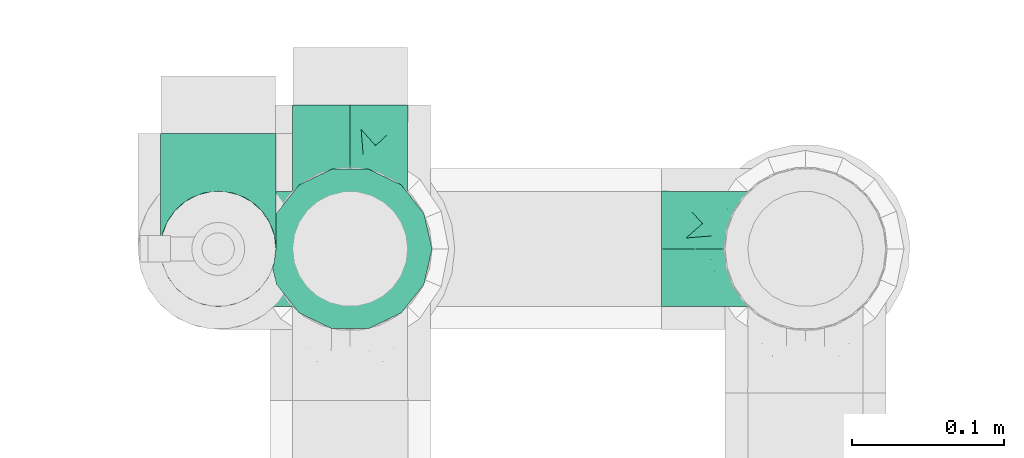
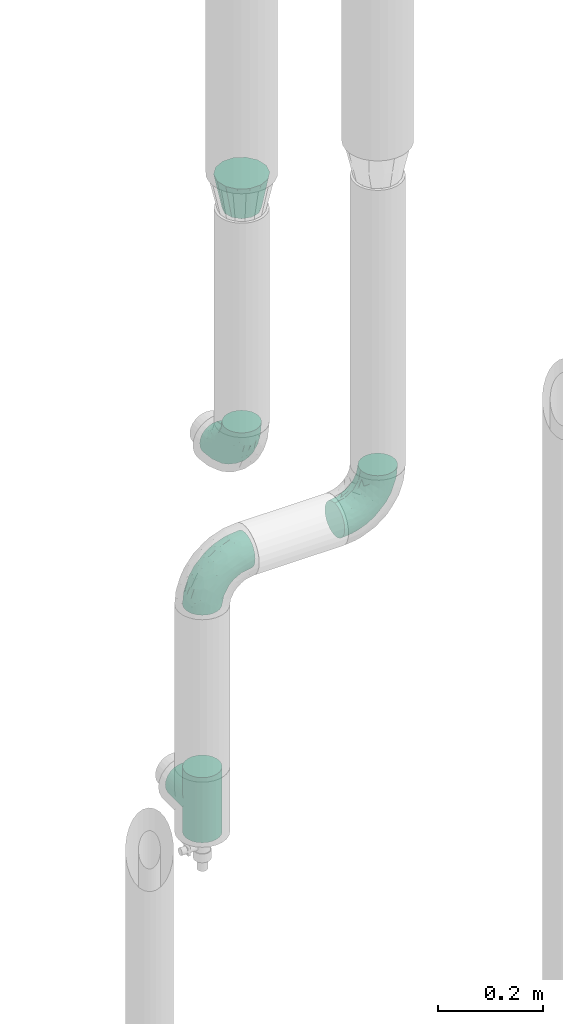
# One storey, part 642 of 827: 5 flow fittings.
"""IFC2X3 building model written with IfcOpenShell, lengths in millimetres."""

from ifc_helpers import new_model, entity, si_unit, converted_unit, derived_unit, direction, frame, origin, place, context, subcontext, project, spatial, faceted_brep, source, transform, mapped, material, type_object, type_shapes, element, save


model = new_model("IFC2X3")

# Units and contexts
model_context = context("Model", 3, precision=0.01, world=origin(), true_north=direction((6.12303176911189e-17, 1.0)))
body_context = subcontext(model_context, "Body", "Model", "MODEL_VIEW")
ifc_project = project(units=[si_unit("LENGTHUNIT", "METRE", prefix="MILLI"), si_unit("AREAUNIT", "SQUARE_METRE"), si_unit("VOLUMEUNIT", "CUBIC_METRE"), converted_unit("PLANEANGLEUNIT", "DEGREE", entity("IfcRatioMeasure", 0.0174532925199433), si_unit("PLANEANGLEUNIT", "RADIAN"), dimensions=[0, 0, 0, 0, 0, 0, 0]), si_unit("MASSUNIT", "GRAM", prefix="KILO"), derived_unit("MASSDENSITYUNIT", [(si_unit("MASSUNIT", "GRAM", prefix="KILO"), 1), (si_unit("LENGTHUNIT", "METRE"), -3)]), derived_unit("MOMENTOFINERTIAUNIT", [(si_unit("LENGTHUNIT", "METRE"), 4)]), si_unit("TIMEUNIT", "SECOND"), si_unit("FREQUENCYUNIT", "HERTZ"), si_unit("THERMODYNAMICTEMPERATUREUNIT", "DEGREE_CELSIUS"), derived_unit("THERMALTRANSMITTANCEUNIT", [(si_unit("MASSUNIT", "GRAM", prefix="KILO"), 1), (si_unit("THERMODYNAMICTEMPERATUREUNIT", "KELVIN"), -1), (si_unit("TIMEUNIT", "SECOND"), -3)]), derived_unit("VOLUMETRICFLOWRATEUNIT", [(si_unit("LENGTHUNIT", "METRE"), 3), (si_unit("TIMEUNIT", "SECOND"), -1)]), derived_unit("MASSFLOWRATEUNIT", [(si_unit("MASSUNIT", "GRAM", prefix="KILO"), 1), (si_unit("TIMEUNIT", "SECOND"), -1)]), derived_unit("ROTATIONALFREQUENCYUNIT", [(si_unit("TIMEUNIT", "SECOND"), -1)]), si_unit("ELECTRICCURRENTUNIT", "AMPERE"), si_unit("ELECTRICVOLTAGEUNIT", "VOLT"), si_unit("POWERUNIT", "WATT"), si_unit("FORCEUNIT", "NEWTON", prefix="KILO"), si_unit("ILLUMINANCEUNIT", "LUX"), si_unit("LUMINOUSFLUXUNIT", "LUMEN"), si_unit("LUMINOUSINTENSITYUNIT", "CANDELA"), derived_unit("USERDEFINED", [(si_unit("MASSUNIT", "GRAM", prefix="KILO"), -1), (si_unit("LENGTHUNIT", "METRE"), -2), (si_unit("TIMEUNIT", "SECOND"), 3), (si_unit("LUMINOUSFLUXUNIT", "LUMEN"), 1)]), derived_unit("LINEARVELOCITYUNIT", [(si_unit("LENGTHUNIT", "METRE"), 1), (si_unit("TIMEUNIT", "SECOND"), -1)]), si_unit("PRESSUREUNIT", "PASCAL"), derived_unit("USERDEFINED", [(si_unit("LENGTHUNIT", "METRE"), -2), (si_unit("MASSUNIT", "GRAM", prefix="KILO"), 1), (si_unit("TIMEUNIT", "SECOND"), -2)]), derived_unit("LINEARFORCEUNIT", [(si_unit("MASSUNIT", "GRAM", prefix="KILO"), 1), (si_unit("LENGTHUNIT", "METRE"), 1), (si_unit("TIMEUNIT", "SECOND"), -2), (si_unit("LENGTHUNIT", "METRE"), -1)]), derived_unit("PLANARFORCEUNIT", [(si_unit("MASSUNIT", "GRAM", prefix="KILO"), 1), (si_unit("LENGTHUNIT", "METRE"), 1), (si_unit("TIMEUNIT", "SECOND"), -2), (si_unit("LENGTHUNIT", "METRE"), -2)])], contexts=[model_context])

# Site, building, storey
site_placement = place(None, origin())
site = spatial("IfcSite", under=ifc_project, at=site_placement, CompositionType="ELEMENT")
building_placement = place(site_placement, origin())
building = spatial("IfcBuilding", under=site, at=building_placement, CompositionType="ELEMENT")
storey_placement = place(building_placement, frame((0.0, 0.0, 28200.0)))
storey = spatial("IfcBuildingStorey", under=building, at=storey_placement, Name="08", CompositionType="ELEMENT", Elevation=28200.0)

# Flow fittings
ifc_material = material()
pipe_fitting_type_1 = type_object("IfcPipeFittingType", Name="ADSK_1", PredefinedType="NOTDEFINED", material=ifc_material)
shared_shape_1 = source(origin(), body_context, "Body", "Brep", [
    faceted_brep([(-95.0, 19.02, -32.95), (-95.0, 9.85, -36.75), (-95.0, 0.0, -38.05), (-95.0, -9.85, -36.75), (-95.0, -19.03, -32.95), (-95.0, -26.91, -26.91), (-95.0, -32.95, -19.03), (-95.0, -36.75, -9.85), (-95.0, -38.05, 0.0), (-95.0, -36.75, 9.85), (-95.0, -32.95, 19.02), (-95.0, -26.91, 26.91), (-95.0, -19.03, 32.95), (-95.0, -9.85, 36.75), (-95.0, 0.0, 38.05), (-95.0, 9.85, 36.75), (-95.0, 19.02, 32.95), (-95.0, 26.91, 26.91), (-95.0, 32.95, 19.02), (-95.0, 36.75, 9.85), (-95.0, 38.05, 0.0), (-95.0, 36.75, -9.85), (-95.0, 32.95, -19.03), (-95.0, 26.91, -26.91), (0.0, 95.0, -38.05), (-9.85, 95.0, -36.75), (-19.02, 95.0, -32.95), (-26.91, 95.0, -26.91), (-32.95, 95.0, -19.03), (-36.75, 95.0, -9.85), (-38.05, 95.0, 0.0), (-36.75, 95.0, 9.85), (-32.95, 95.0, 19.02), (-26.91, 95.0, 26.91), (-19.02, 95.0, 32.95), (-9.85, 95.0, 36.75), (0.0, 95.0, 38.05), (9.85, 95.0, 36.75), (19.03, 95.0, 32.95), (26.91, 95.0, 26.91), (32.95, 95.0, 19.02), (36.75, 95.0, 9.85), (38.05, 95.0, 0.0), (36.75, 95.0, -9.85), (32.95, 95.0, -19.03), (26.91, 95.0, -26.91), (19.03, 95.0, -32.95), (9.85, 95.0, -36.75), (-7.99, -4.96, 6.3), (-0.92, 0.92, 0.0), (4.62, 8.1, 8.01), (-76.19, -35.57, 0.0), (-64.32, -32.32, 12.43), (20.51, 62.45, 28.68), (-60.56, -33.52, 0.0), (-70.4, -13.47, 34.42), (-39.61, -5.88, 32.32), (-49.6, 2.07, 37.1), (-70.34, -28.81, 21.71), (14.64, 40.81, 26.5), (5.88, 39.61, 32.32), (3.59, 20.77, 25.31), (-40.45, 68.06, 16.75), (-62.45, -20.51, 28.68), (-44.52, -26.87, 0.0), (-28.47, -20.22, 0.0), (-26.43, -17.83, 8.75), (-76.1, 39.63, 10.76), (-72.74, 37.58, 18.19), (-60.35, 46.18, 14.61), (-13.4, 13.4, 32.12), (-20.77, -3.59, 25.31), (-14.66, 81.47, 35.56), (-6.22, 71.26, 37.92), (-57.5, 42.48, 22.79), (-15.0, 34.74, 37.7), (-27.1, 12.08, 36.05), (-9.2, 28.81, 35.63), (-79.98, 23.7, 30.95), (-73.68, -4.3, 37.48), (-30.74, 21.67, 37.97), (-62.36, 47.59, 6.79), (-72.71, 32.83, 24.69), (-67.42, 7.02, 37.95), (-32.13, 75.27, 24.51), (-43.46, 51.47, 26.26), (-24.98, 73.15, 31.29), (20.59, 41.28, 19.85), (7.79, 16.09, 15.86), (-73.21, 42.39, 0.0), (-54.73, 54.73, 0.0), (-73.44, 15.79, 35.79), (-5.94, 4.32, 20.43), (28.81, 70.34, 21.71), (32.32, 64.32, 12.43), (-53.59, 26.2, 35.09), (-52.02, 19.31, 37.21), (21.38, 33.53, 10.34), (26.87, 44.52, 0.0), (-48.28, 12.14, 38.05), (4.3, 73.68, 37.48), (-44.08, -25.52, 12.79), (-41.28, -20.59, 19.85), (35.57, 76.19, 0.0), (-47.26, 54.3, 20.18), (-47.4, 61.99, 8.58), (-42.39, 73.21, 0.0), (-39.67, 78.86, 7.21), (-45.69, 36.84, 33.11), (-32.83, 50.13, 33.35), (13.47, 70.4, 34.42), (-18.25, 63.73, 36.07), (-40.63, -13.75, 27.22), (-16.63, 46.37, 37.95), (-53.47, 38.79, 28.59), (-26.07, 48.54, 36.15), (-34.51, 34.51, 36.86), (-2.07, 49.6, 37.1), (-22.79, -10.49, 19.23), (-61.73, 28.67, 31.87), (9.65, 14.7, 0.0), (20.22, 28.47, 0.0), (33.52, 60.56, 0.0), (-11.42, -5.44, 13.25), (-14.7, -9.65, 0.0), (-81.47, 14.66, -35.56), (-62.45, -20.51, -28.68), (-71.26, 6.22, -37.92), (-75.27, 32.13, -24.51), (-73.15, 24.98, -31.29), (13.47, 70.4, -34.42), (5.88, 39.61, -32.32), (-2.07, 49.6, -37.1), (-78.86, 39.67, -7.21), (-70.4, -13.47, -34.42), (-39.61, -5.88, -32.32), (-61.99, 47.4, -8.58), (32.32, 64.32, -12.43), (28.81, 70.34, -21.71), (-63.73, 18.25, -36.07), (-50.13, 32.83, -33.35), (4.3, 73.68, -37.48), (-7.02, 67.42, -37.95), (-39.63, 76.1, -10.76), (-46.18, 60.35, -14.61), (-47.59, 62.36, -6.79), (-64.32, -32.32, -12.43), (-26.2, 53.59, -35.09), (-15.79, 73.44, -35.79), (-19.31, 52.02, -37.21), (-37.58, 72.74, -18.19), (-70.34, -28.81, -21.71), (-42.48, 57.5, -22.79), (-38.79, 53.47, -28.59), (-51.47, 43.46, -26.26), (-32.83, 72.71, -24.69), (-46.37, 16.63, -37.95), (-73.68, -4.3, -37.48), (-41.28, -20.59, -19.85), (-44.08, -25.52, -12.79), (13.75, 40.63, -27.22), (20.51, 62.45, -28.68), (-68.06, 40.45, -16.75), (-54.3, 47.26, -20.18), (-12.14, 48.28, -38.05), (-21.67, 30.74, -37.97), (-36.84, 45.69, -33.11), (-11.42, -5.44, -13.25), (7.79, 16.09, -15.86), (4.62, 8.1, -8.01), (-23.7, 79.98, -30.95), (-26.43, -17.83, -8.75), (-7.99, -4.96, -6.3), (-40.81, -14.64, -26.5), (-20.77, -3.59, -25.31), (-34.74, 15.0, -37.7), (-12.08, 27.1, -36.05), (-28.81, 9.2, -35.63), (-22.79, -10.49, -19.23), (21.38, 33.53, -10.34), (20.59, 41.28, -19.85), (-48.54, 26.07, -36.15), (-49.6, 2.07, -37.1), (-13.4, 13.4, -32.12), (3.59, 20.77, -25.31), (-28.67, 61.73, -31.87), (-34.51, 34.51, -36.86), (-5.94, 4.32, -20.43)], [[[0, 1, 2, 3, 4, 5, 6, 7, 8, 9, 10, 11, 12, 13, 14, 15, 16, 17, 18, 19, 20, 21, 22, 23]], [[24, 25, 26, 27, 28, 29, 30, 31, 32, 33, 34, 35, 36, 37, 38, 39, 40, 41, 42, 43, 44, 45, 46, 47]], [[48, 49, 50]], [[51, 52, 9]], [[53, 39, 38]], [[9, 52, 10]], [[54, 52, 51]], [[55, 56, 57]], [[11, 10, 58]], [[59, 60, 61]], [[32, 31, 62]], [[63, 12, 11]], [[63, 55, 12]], [[64, 65, 66]], [[67, 68, 69]], [[70, 56, 71]], [[35, 72, 73]], [[69, 68, 74]], [[75, 76, 77]], [[16, 78, 17]], [[13, 79, 14]], [[76, 75, 80]], [[67, 69, 81]], [[18, 17, 82]], [[14, 79, 83]], [[20, 19, 67]], [[84, 85, 86]], [[87, 61, 88]], [[89, 81, 90]], [[18, 82, 68]], [[15, 91, 16]], [[14, 83, 15]], [[71, 92, 61]], [[17, 78, 82]], [[93, 87, 94]], [[95, 91, 96]], [[97, 98, 94]], [[86, 72, 34]], [[96, 99, 80]], [[37, 36, 100]], [[40, 39, 93]], [[40, 94, 41]], [[64, 66, 101]], [[93, 94, 40]], [[58, 102, 63]], [[94, 103, 41]], [[94, 87, 97]], [[104, 69, 74]], [[34, 33, 86]], [[105, 69, 104]], [[52, 58, 10]], [[106, 107, 30]], [[108, 109, 85]], [[105, 106, 90]], [[53, 110, 60]], [[86, 111, 72]], [[86, 109, 111]], [[33, 84, 86]], [[12, 55, 13]], [[112, 56, 63]], [[110, 38, 37]], [[34, 72, 35]], [[36, 35, 73]], [[111, 113, 73]], [[105, 107, 106]], [[110, 53, 38]], [[74, 114, 85]], [[91, 15, 83]], [[105, 90, 81]], [[107, 62, 31]], [[33, 32, 84]], [[115, 109, 116]], [[111, 115, 113]], [[100, 73, 117]], [[56, 55, 63]], [[79, 55, 57]], [[102, 118, 112]], [[56, 70, 76]], [[100, 110, 37]], [[117, 77, 60]], [[117, 60, 110]], [[60, 70, 61]], [[58, 52, 101]], [[63, 11, 58]], [[39, 53, 93]], [[87, 93, 53]], [[96, 91, 83]], [[78, 91, 119]], [[32, 62, 84]], [[84, 62, 104]], [[86, 85, 109]], [[85, 114, 108]], [[80, 113, 116]], [[117, 73, 113]], [[80, 116, 96]], [[80, 57, 76]], [[71, 112, 118]], [[61, 87, 59]], [[62, 107, 105]], [[97, 120, 121]], [[70, 71, 61]], [[71, 118, 92]], [[73, 100, 36]], [[110, 100, 117]], [[55, 79, 13]], [[83, 79, 57]], [[96, 83, 99]], [[116, 108, 95]], [[50, 97, 88]], [[97, 87, 88]], [[50, 49, 120]], [[122, 94, 98]], [[89, 20, 67]], [[105, 81, 69]], [[89, 67, 81]], [[68, 19, 18]], [[68, 67, 19]], [[74, 68, 82]], [[114, 82, 119]], [[74, 85, 104]], [[82, 114, 74]], [[114, 119, 108]], [[95, 108, 119]], [[116, 109, 108]], [[123, 48, 50]], [[97, 50, 120]], [[123, 50, 88]], [[91, 95, 119]], [[116, 95, 96]], [[84, 104, 85]], [[104, 62, 105]], [[83, 57, 99]], [[57, 80, 99]], [[66, 48, 123]], [[66, 124, 48]], [[118, 66, 123]], [[124, 66, 65]], [[66, 118, 101]], [[54, 64, 52]], [[124, 49, 48]], [[30, 107, 31]], [[91, 78, 16]], [[82, 78, 119]], [[56, 76, 57]], [[77, 76, 70]], [[60, 77, 70]], [[77, 117, 75]], [[117, 113, 75]], [[113, 80, 75]], [[9, 8, 51]], [[103, 94, 122]], [[103, 42, 41]], [[73, 72, 111]], [[113, 115, 116]], [[111, 109, 115]], [[102, 112, 63]], [[71, 56, 112]], [[118, 102, 101]], [[92, 123, 88]], [[123, 92, 118]], [[61, 92, 88]], [[87, 53, 59]], [[60, 59, 53]], [[97, 121, 98]], [[58, 101, 102]], [[64, 101, 52]], [[125, 1, 0]], [[126, 5, 4]], [[2, 1, 127]], [[1, 125, 127]], [[128, 129, 23]], [[130, 131, 132]], [[89, 133, 20]], [[126, 134, 135]], [[136, 89, 90]], [[137, 138, 44]], [[139, 129, 140]], [[24, 141, 142]], [[143, 144, 145]], [[125, 129, 139]], [[6, 146, 7]], [[147, 148, 149]], [[146, 51, 7]], [[143, 150, 144]], [[146, 6, 151]], [[152, 153, 154]], [[126, 4, 134]], [[0, 23, 129]], [[28, 155, 150]], [[43, 42, 103]], [[54, 146, 64]], [[139, 156, 127]], [[157, 3, 2]], [[151, 158, 159]], [[160, 131, 161]], [[22, 21, 162]], [[136, 144, 163]], [[149, 164, 165]], [[24, 142, 25]], [[166, 140, 154]], [[154, 129, 128]], [[143, 30, 29]], [[167, 168, 169]], [[155, 28, 27]], [[26, 170, 27]], [[171, 167, 172]], [[26, 25, 148]], [[27, 170, 155]], [[173, 135, 174]], [[144, 150, 152]], [[175, 176, 177]], [[24, 47, 141]], [[45, 161, 46]], [[148, 25, 142]], [[176, 175, 165]], [[64, 159, 171]], [[138, 45, 44]], [[130, 46, 161]], [[137, 44, 43]], [[178, 159, 158]], [[137, 103, 122]], [[163, 144, 152]], [[136, 133, 89]], [[103, 137, 43]], [[6, 5, 151]], [[178, 158, 173]], [[134, 4, 3]], [[178, 173, 174]], [[137, 98, 179]], [[145, 90, 106]], [[138, 180, 161]], [[46, 130, 47]], [[136, 90, 145]], [[133, 162, 21]], [[23, 22, 128]], [[139, 140, 181]], [[139, 181, 156]], [[157, 127, 182]], [[157, 134, 3]], [[182, 177, 135]], [[182, 135, 134]], [[135, 183, 174]], [[131, 130, 161]], [[141, 130, 132]], [[160, 180, 184]], [[131, 183, 176]], [[5, 126, 151]], [[158, 151, 126]], [[180, 138, 137]], [[161, 45, 138]], [[149, 148, 142]], [[170, 148, 185]], [[22, 162, 128]], [[128, 162, 163]], [[129, 154, 140]], [[154, 153, 166]], [[165, 156, 186]], [[182, 127, 156]], [[165, 186, 149]], [[165, 132, 176]], [[131, 184, 183]], [[187, 167, 178]], [[184, 168, 187]], [[167, 169, 172]], [[184, 180, 168]], [[174, 183, 184]], [[127, 157, 2]], [[134, 157, 182]], [[130, 141, 47]], [[142, 141, 132]], [[149, 142, 164]], [[186, 166, 147]], [[180, 179, 168]], [[169, 179, 120]], [[137, 179, 180]], [[179, 121, 120]], [[106, 30, 143]], [[136, 145, 144]], [[106, 143, 145]], [[150, 29, 28]], [[150, 143, 29]], [[152, 150, 155]], [[153, 155, 185]], [[152, 154, 163]], [[155, 153, 152]], [[153, 185, 166]], [[147, 166, 185]], [[186, 140, 166]], [[169, 120, 49]], [[169, 49, 172]], [[179, 169, 168]], [[148, 147, 185]], [[186, 147, 149]], [[128, 163, 154]], [[163, 162, 136]], [[142, 132, 164]], [[132, 165, 164]], [[171, 124, 65]], [[124, 171, 172]], [[64, 146, 159]], [[171, 159, 178]], [[171, 65, 64]], [[172, 49, 124]], [[162, 133, 136]], [[20, 133, 21]], [[148, 170, 26]], [[155, 170, 185]], [[131, 176, 132]], [[177, 176, 183]], [[135, 177, 183]], [[177, 182, 175]], [[182, 156, 175]], [[156, 165, 175]], [[51, 146, 54]], [[51, 8, 7]], [[129, 125, 0]], [[127, 125, 139]], [[140, 186, 181]], [[156, 181, 186]], [[158, 126, 173]], [[135, 173, 126]], [[187, 178, 174]], [[171, 178, 167]], [[184, 187, 174]], [[167, 187, 168]], [[180, 160, 161]], [[184, 131, 160]], [[98, 137, 122]], [[98, 121, 179]], [[151, 159, 146]]]),
])
type_shapes(pipe_fitting_type_1, [shared_shape_1])
for number, where, z_axis, x_axis, name in (
    (1, (31455.41, 19353.43, 1130.45), (1.0, 0.0, 0.0), (0.0, 0.0, -1.0), "ADSK_1"),
    (2, (31368.41, 19353.43, 925.26), (0.0, 1.0, 0.0), (0.0, 0.0, 1.0), "ADSK_1"),
    (3, (31755.91, 19353.43, 925.26), (0.0, -1.0, 0.0), (1.0, 0.0, 0.0), "ADSK_1"),
):
    element("IfcFlowFitting", number, at=place(storey_placement, frame(where, z_axis=z_axis, x_axis=x_axis)), inside=storey, type_object=pipe_fitting_type_1, material=ifc_material, Name=name, ObjectType="ADSK_1", context=body_context, shape_type="MappedRepresentation", body=[
        mapped(shared_shape_1, transform((0.0, 0.0, 0.0), scale=1.0)),
    ])
pipe_fitting_type_2 = type_object("IfcPipeFittingType", Name="ADSK_1", PredefinedType="NOTDEFINED", material=ifc_material)
shared_shape_2 = source(origin(), body_context, "Body", "Brep", [
    faceted_brep([(-76.0, 9.85, -36.75), (-76.0, 0.0, -38.05), (-76.0, -9.85, -36.75), (-76.0, -19.03, -32.95), (-76.0, -22.97, -29.93), (-76.0, -26.91, -26.91), (-76.0, -29.93, -22.97), (-76.0, -32.95, -19.03), (-76.0, -34.85, -14.44), (-76.0, -36.75, -9.85), (-76.0, -38.05, 0.0), (-76.0, -36.75, 9.85), (-76.0, -34.85, 14.44), (-76.0, -32.95, 19.02), (-76.0, -29.93, 22.97), (-76.0, -26.91, 26.91), (-76.0, -22.97, 29.93), (-76.0, -19.03, 32.95), (-76.0, -9.85, 36.75), (-76.0, 0.0, 38.05), (-76.0, 9.85, 36.75), (-76.0, 19.02, 32.95), (-76.0, 26.91, 26.91), (-76.0, 32.95, 19.02), (-76.0, 36.75, 9.85), (-76.0, 38.05, 0.0), (-76.0, 36.75, -9.85), (-76.0, 32.95, -19.03), (-76.0, 26.91, -26.91), (-76.0, 19.02, -32.95), (76.0, 26.91, -26.91), (76.0, 32.95, -19.03), (76.0, 36.75, -9.85), (76.0, 38.05, 0.0), (76.0, 36.75, 9.85), (76.0, 32.95, 19.02), (76.0, 26.91, 26.91), (76.0, 19.02, 32.95), (76.0, 9.85, 36.75), (76.0, 0.0, 38.05), (76.0, -9.85, 36.75), (76.0, -19.03, 32.95), (76.0, -22.97, 29.93), (76.0, -26.91, 26.91), (76.0, -29.93, 22.97), (76.0, -32.95, 19.02), (76.0, -34.85, 14.44), (76.0, -36.75, 9.85), (76.0, -38.05, 0.0), (76.0, -36.75, -9.85), (76.0, -34.85, -14.44), (76.0, -32.95, -19.03), (76.0, -29.93, -22.97), (76.0, -26.91, -26.91), (76.0, -22.97, -29.93), (76.0, -19.03, -32.95), (76.0, -9.85, -36.75), (76.0, 0.0, -38.05), (76.0, 9.85, -36.75), (76.0, 19.02, -32.95), (36.99, -36.99, 8.94), (38.05, -38.05, 0.0), (-36.99, -36.99, 8.94), (-38.05, -38.05, 0.0), (35.51, -35.51, 12.97), (34.04, -34.04, 17.0), (18.81, -18.81, 33.08), (29.74, -29.74, 23.73), (24.56, -24.56, 29.06), (-35.51, -35.51, 12.97), (-34.04, -34.04, 17.0), (-18.81, -18.81, 33.08), (-29.74, -29.74, 23.73), (-24.56, -24.56, 29.06), (-12.7, -12.7, 35.87), (6.4, -6.4, 37.51), (12.7, -12.7, 35.87), (0.0, 0.0, 38.05), (-6.4, -6.4, 37.51), (6.4, -6.4, -37.51), (0.0, 0.0, -38.05), (12.7, -12.7, -35.87), (-24.56, -24.56, -29.06), (-6.4, -6.4, -37.51), (-35.51, -35.51, -12.97), (-36.99, -36.99, -8.94), (-29.74, -29.74, -23.73), (-12.7, -12.7, -35.87), (18.81, -18.81, -33.08), (24.56, -24.56, -29.06), (-34.04, -34.04, -17.0), (29.74, -29.74, -23.73), (36.99, -36.99, -8.94), (35.51, -35.51, -12.97), (34.04, -34.04, -17.0), (-18.81, -18.81, -33.08), (9.85, -76.0, -36.75), (19.03, -76.0, -32.95), (26.91, -76.0, -26.91), (32.95, -76.0, -19.03), (36.75, -76.0, -9.85), (38.05, -76.0, 0.0), (36.75, -76.0, 9.85), (32.95, -76.0, 19.02), (26.91, -76.0, 26.91), (19.03, -76.0, 32.95), (9.85, -76.0, 36.75), (0.0, -76.0, 38.05), (-9.85, -76.0, 36.75), (-19.02, -76.0, 32.95), (-26.91, -76.0, 26.91), (-32.95, -76.0, 19.02), (-36.75, -76.0, 9.85), (-38.05, -76.0, 0.0), (-36.75, -76.0, -9.85), (-32.95, -76.0, -19.03), (-26.91, -76.0, -26.91), (-19.02, -76.0, -32.95), (-9.85, -76.0, -36.75), (0.0, -76.0, -38.05)], [[[0, 1, 2, 3, 4, 5, 6, 7, 8, 9, 10, 11, 12, 13, 14, 15, 16, 17, 18, 19, 20, 21, 22, 23, 24, 25, 26, 27, 28, 29]], [[30, 31, 32, 33, 34, 35, 36, 37, 38, 39, 40, 41, 42, 43, 44, 45, 46, 47, 48, 49, 50, 51, 52, 53, 54, 55, 56, 57, 58, 59]], [[48, 47, 60]], [[60, 61, 48]], [[62, 10, 63]], [[47, 46, 64]], [[46, 45, 65]], [[41, 66, 42]], [[43, 67, 45, 44]], [[67, 43, 68]], [[45, 67, 65]], [[68, 43, 42]], [[11, 69, 12]], [[70, 12, 69]], [[10, 62, 11]], [[11, 62, 69]], [[71, 17, 16]], [[72, 73, 15]], [[72, 15, 14, 13]], [[15, 73, 16]], [[71, 74, 17]], [[72, 13, 70]], [[46, 65, 64]], [[42, 66, 68]], [[40, 39, 75]], [[47, 64, 60]], [[66, 41, 76]], [[75, 76, 40]], [[75, 39, 77]], [[78, 77, 19]], [[76, 41, 40]], [[23, 22, 36, 35]], [[24, 23, 35, 34]], [[21, 20, 38, 37]], [[22, 21, 37, 36]], [[38, 20, 19, 77, 39]], [[25, 24, 34, 33]], [[70, 13, 12]], [[78, 18, 74]], [[18, 78, 19]], [[18, 17, 74]], [[71, 16, 73]], [[28, 27, 31, 30]], [[26, 32, 31, 27]], [[25, 33, 32, 26]], [[29, 28, 30, 59]], [[57, 56, 79]], [[58, 57, 80, 1, 0]], [[79, 56, 81]], [[82, 5, 4]], [[59, 58, 0, 29]], [[56, 55, 81]], [[57, 79, 80]], [[80, 83, 1]], [[9, 84, 85]], [[86, 7, 6, 5]], [[83, 87, 2]], [[1, 83, 2]], [[87, 3, 2]], [[88, 54, 89]], [[54, 53, 89]], [[8, 90, 84]], [[88, 55, 54]], [[91, 89, 53]], [[52, 51, 91, 53]], [[55, 88, 81]], [[49, 92, 93]], [[92, 49, 48]], [[94, 50, 93]], [[61, 92, 48]], [[85, 63, 10]], [[51, 94, 91]], [[82, 4, 95]], [[49, 93, 50]], [[4, 3, 95]], [[5, 82, 86]], [[94, 51, 50]], [[95, 3, 87]], [[9, 8, 84]], [[90, 8, 7]], [[9, 85, 10]], [[90, 7, 86]], [[96, 97, 98, 99, 100, 101, 102, 103, 104, 105, 106, 107, 108, 109, 110, 111, 112, 113, 114, 115, 116, 117, 118, 119]], [[62, 63, 113]], [[112, 62, 113]], [[110, 109, 73]], [[72, 111, 110]], [[70, 112, 111]], [[74, 109, 108]], [[112, 70, 69, 62]], [[73, 72, 110]], [[70, 111, 72]], [[74, 71, 109]], [[107, 77, 78]], [[74, 108, 78]], [[73, 109, 71]], [[78, 108, 107]], [[75, 107, 106]], [[105, 76, 106]], [[103, 102, 65]], [[67, 104, 103]], [[68, 105, 104]], [[60, 102, 101]], [[68, 66, 105]], [[76, 75, 106]], [[66, 76, 105]], [[61, 60, 101]], [[65, 67, 103]], [[102, 60, 64, 65]], [[68, 104, 67]], [[107, 75, 77]], [[61, 101, 92]], [[100, 92, 101]], [[98, 97, 89]], [[94, 100, 99]], [[98, 91, 99]], [[81, 97, 96]], [[100, 94, 93, 92]], [[89, 91, 98]], [[94, 99, 91]], [[81, 88, 97]], [[119, 80, 79]], [[81, 96, 79]], [[89, 97, 88]], [[79, 96, 119]], [[83, 119, 118]], [[117, 87, 118]], [[115, 114, 90]], [[86, 116, 115]], [[82, 117, 116]], [[85, 114, 113]], [[82, 95, 117]], [[87, 83, 118]], [[95, 87, 117]], [[63, 85, 113]], [[90, 86, 115]], [[114, 85, 84, 90]], [[82, 116, 86]], [[119, 83, 80]]]),
])
type_shapes(pipe_fitting_type_2, [shared_shape_2])
flow_fitting_1_placement = place(storey_placement, frame((31368.41, 19353.43, 375.0), z_axis=(-1.0, 0.0, 0.0), x_axis=(0.0, 0.0, -1.0)))
element("IfcFlowFitting", 4, at=flow_fitting_1_placement, inside=storey, type_object=pipe_fitting_type_2, material=ifc_material, Name="ADSK_1", ObjectType="ADSK_1", context=body_context, shape_type="MappedRepresentation", body=[
    mapped(shared_shape_2, transform((0.0, 0.0, 0.0), scale=1.0)),
])
pipe_fitting_type_3 = type_object("IfcPipeFittingType", Name="ADSK_2", PredefinedType="NOTDEFINED", material=ifc_material)
shared_shape_3 = source(origin(), body_context, "Body", "Brep", [
    faceted_brep([(80.0, -19.0, 32.91), (80.0, -25.95, 25.95), (80.0, -32.91, 19.0), (80.0, -35.45, 9.5), (80.0, -38.0, 0.0), (80.0, -35.45, -9.5), (80.0, -32.91, -19.0), (80.0, -25.95, -25.95), (80.0, -19.0, -32.91), (80.0, -9.5, -35.45), (80.0, 0.0, -38.0), (80.0, 9.5, -35.45), (80.0, 19.0, -32.91), (80.0, 25.95, -25.95), (80.0, 32.91, -19.0), (80.0, 35.45, -9.5), (80.0, 38.0, 0.0), (80.0, 35.45, 9.5), (80.0, 32.91, 19.0), (80.0, 25.95, 25.95), (80.0, 19.0, 32.91), (80.0, 9.5, 35.45), (80.0, 0.0, 38.0), (80.0, -9.5, 35.45), (0.0, 22.84, 47.43), (0.0, 33.67, 42.22), (0.0, 41.16, 32.82), (0.0, 48.65, 23.43), (0.0, 51.33, 11.71), (0.0, 54.0, 0.0), (0.0, 51.33, -11.71), (0.0, 48.65, -23.43), (0.0, 41.16, -32.82), (0.0, 33.67, -42.22), (0.0, 22.84, -47.43), (0.0, 12.02, -52.65), (0.0, 0.0, -52.65), (0.0, -12.02, -52.65), (0.0, -22.84, -47.43), (0.0, -33.67, -42.22), (0.0, -41.16, -32.82), (0.0, -48.65, -23.43), (0.0, -51.33, -11.71), (0.0, -54.0, 0.0), (0.0, -51.33, 11.71), (0.0, -48.65, 23.43), (0.0, -41.16, 32.82), (0.0, -33.67, 42.22), (0.0, -22.84, 47.43), (0.0, -12.02, 52.65), (0.0, 0.0, 52.65), (0.0, 12.02, 52.65)], [[[0, 1, 2, 3, 4, 5, 6, 7, 8, 9, 10, 11, 12, 13, 14, 15, 16, 17, 18, 19, 20, 21, 22, 23]], [[24, 25, 26, 27, 28, 29, 30, 31, 32, 33, 34, 35, 36, 37, 38, 39, 40, 41, 42, 43, 44, 45, 46, 47, 48, 49, 50, 51]], [[15, 31, 30]], [[42, 4, 43]], [[32, 31, 14]], [[14, 31, 15]], [[34, 11, 35]], [[4, 42, 5]], [[13, 12, 33]], [[10, 37, 36, 35]], [[8, 39, 38]], [[39, 8, 7]], [[38, 9, 8]], [[34, 33, 12]], [[11, 10, 35]], [[40, 6, 41]], [[13, 33, 32]], [[16, 15, 30]], [[38, 37, 9]], [[16, 30, 29]], [[41, 6, 5]], [[6, 40, 7]], [[14, 13, 32]], [[11, 34, 12]], [[37, 10, 9]], [[40, 39, 7]], [[42, 41, 5]], [[3, 45, 44]], [[28, 16, 29]], [[46, 45, 2]], [[2, 45, 3]], [[48, 23, 49]], [[16, 28, 17]], [[1, 0, 47]], [[22, 51, 50, 49]], [[20, 25, 24]], [[25, 20, 19]], [[24, 21, 20]], [[48, 47, 0]], [[23, 22, 49]], [[26, 18, 27]], [[1, 47, 46]], [[4, 3, 44]], [[24, 51, 21]], [[4, 44, 43]], [[27, 18, 17]], [[18, 26, 19]], [[2, 1, 46]], [[23, 48, 0]], [[51, 22, 21]], [[26, 25, 19]], [[28, 27, 17]]]),
])
type_shapes(pipe_fitting_type_3, [shared_shape_3])
flow_fitting_2_placement = place(storey_placement, frame((31455.41, 19353.43, 1805.45), z_axis=(0.0, -1.0, 0.0), x_axis=(0.0, 0.0, -1.0)))
element("IfcFlowFitting", 5, at=flow_fitting_2_placement, inside=storey, type_object=pipe_fitting_type_3, material=ifc_material, Name="ADSK_2", ObjectType="ADSK_2", context=body_context, shape_type="MappedRepresentation", body=[
    mapped(shared_shape_3, transform((0.0, 0.0, 0.0), scale=1.0)),
])

save(model, "model.ifc")
